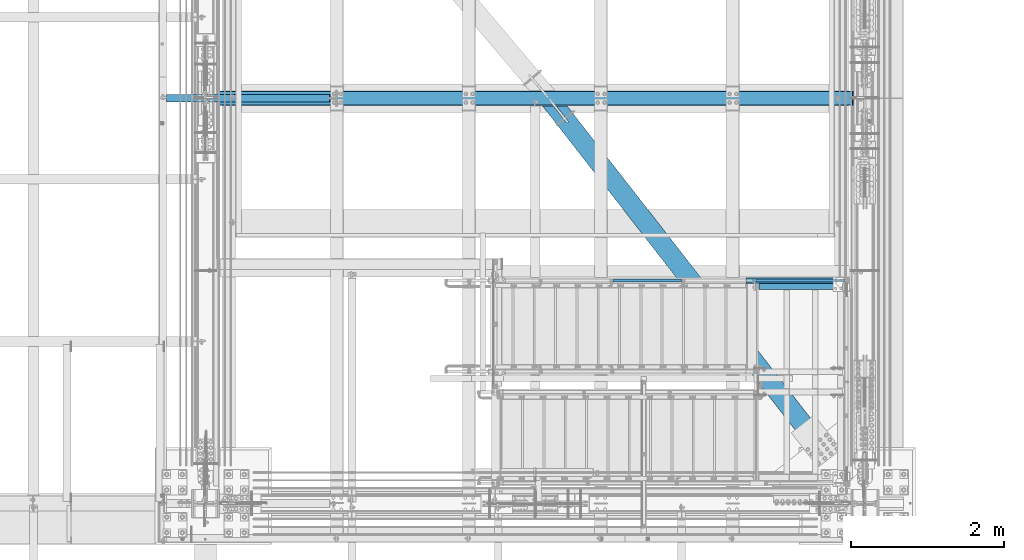
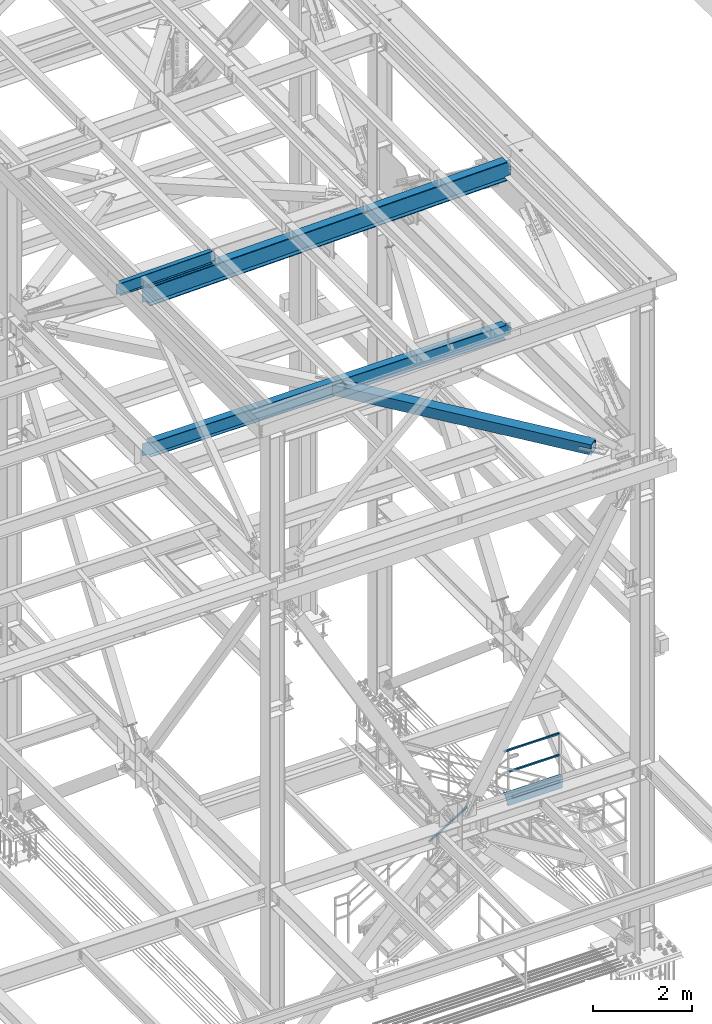
# One storey, part 1950 of 3843: 8 beams, 1 member, 6 elements without a shape of their own.
"""IFC2X3 building model written with IfcOpenShell, lengths in millimetres."""

from ifc_helpers import new_model, si_unit, frame, origin_with_axes, place, context, subcontext, project, spatial, faceted_brep, material, type_object, element, aggregate, save


model = new_model("IFC2X3")

# Units and contexts
model_context = context("Model", 3, precision=1e-05, world=origin_with_axes())
body_context = subcontext(model_context, "Body", "Model", "MODEL_VIEW")
ifc_project = project(units=[si_unit("LENGTHUNIT", "METRE", prefix="MILLI"), si_unit("AREAUNIT", "SQUARE_METRE"), si_unit("VOLUMEUNIT", "CUBIC_METRE"), si_unit("MASSUNIT", "GRAM", prefix="KILO"), si_unit("TIMEUNIT", "SECOND"), si_unit("PLANEANGLEUNIT", "RADIAN"), si_unit("SOLIDANGLEUNIT", "STERADIAN"), si_unit("THERMODYNAMICTEMPERATUREUNIT", "DEGREE_CELSIUS"), si_unit("LUMINOUSINTENSITYUNIT", "LUMEN")], contexts=[model_context])

# Site, building, storey
site_placement = place(None, origin_with_axes())
site = spatial("IfcSite", under=ifc_project, at=site_placement, CompositionType="ELEMENT")
building_placement = place(site_placement, origin_with_axes())
building = spatial("IfcBuilding", under=site, at=building_placement, Name="Undefined", CompositionType="ELEMENT")
storey_placement = place(building_placement, origin_with_axes())
storey = spatial("IfcBuildingStorey", under=building, at=storey_placement, Name="Undefined", CompositionType="ELEMENT", Elevation=0.0)

# Assembly, beams, member
assembly_1_placement = place(storey_placement, origin_with_axes())
assembly_1 = element("IfcElementAssembly", 1, at=assembly_1_placement, inside=storey, Name="RAIL", AssemblyPlace="NOTDEFINED", PredefinedType="RIGID_FRAME")
ifc_material_1 = material()
beam_type_1 = type_object("IfcBeamType", Name="HSS1-1/2X1-1/2X1/4", PredefinedType="NOTDEFINED")
beam_1_placement = place(assembly_1_placement, frame((84200.9999999997, 17919.7, 33248.5999999847), z_axis=(0.0, 0.0, 1.0), x_axis=(1.0, 0.0, 0.0)))
beam_1 = element("IfcBeam", 2, at=beam_1_placement, type_object=beam_type_1, material=ifc_material_1, Name="RAIL", ObjectType="HSS1-1/2X1-1/2X1/4", context=body_context, shape_type="Brep", body=[
    faceted_brep([(19.0499992350015, -19.0499992350015, -19.0499992350015), (19.0499992350015, -19.0499992350015, 19.0499992350015), (19.0499992350015, 19.0499992350015, 19.0499992350015), (19.0499992350015, 19.0499992350015, -19.0499992350015), (19.0499992350015, 12.6999993299978, 12.6999993299978), (19.0499992350015, -12.6999993299978, 12.6999993299978), (19.0499992350015, -12.6999993299978, -12.6999993299978), (19.0499992350015, 12.6999993299978, -12.6999993299978), (1187.45000073145, 19.0499992350015, -19.0499992350015), (1187.45000073145, -19.0499992350015, -19.0499992350015), (1187.45000073145, -19.0499992350015, 19.0499992350015), (1187.45000073145, 19.0499992350015, 19.0499992350015), (1187.44999761864, -12.6999993299978, 12.6999993300014), (1187.44999761864, 12.6999993299978, 12.6999993300014), (1187.44999761864, 12.6999993299978, -12.6999993300014), (1187.44999761864, -12.6999993299978, -12.6999993300014)], [[[0, 1, 2, 3], [4, 5, 6, 7]], [[8, 9, 0, 3]], [[9, 10, 1, 0]], [[10, 11, 2, 1]], [[11, 8, 3, 2]], [[10, 9, 8, 11], [12, 13, 14, 15]], [[13, 12, 5, 4]], [[14, 13, 4, 7]], [[15, 14, 7, 6]], [[12, 15, 6, 5]]]),
])
beam_2_placement = place(assembly_1_placement, frame((85255.0999999997, 17919.7, 33781.9999999847), z_axis=(0.0, 0.0, -1.0), x_axis=(-1.0, 0.0, 0.0)))
beam_2 = element("IfcBeam", 3, at=beam_2_placement, type_object=beam_type_1, material=ifc_material_1, Name="RAIL", ObjectType="HSS1-1/2X1-1/2X1/4", context=body_context, shape_type="Brep", body=[
    faceted_brep([(-133.350000731458, 12.6999993300014, -12.6999993299978), (-133.350000731458, -12.6999993300014, -12.6999993299978), (1159.29463566931, -12.6999993300014, -12.6999993299978), (1159.29463566931, 12.6999993300014, -12.6999993299978), (-133.350000731458, -12.6999993300014, 12.6999993299978), (1152.10536442048, -12.6999993300014, 12.6999993299978), (-133.350000731458, 12.6999993300014, 12.6999993299978), (1152.10536442048, 12.6999993300014, 12.6999993299978), (-133.350000731458, 19.0499992350015, -19.0499992350015), (-133.350000731458, 19.0499992350015, 19.0499992350015), (1150.30804654033, 19.0499992350015, 19.0499992350015), (1161.09195354945, 19.0499992350015, -19.0499992350015), (-133.350000731458, -19.0499992350015, 19.0499992350015), (1150.30804654033, -19.0499992350015, 19.0499992350015), (-133.350000731458, -19.0499992350015, -19.0499992350015), (1161.09195354945, -19.0499992350015, -19.0499992350015)], [[[0, 1, 2, 3]], [[1, 4, 5, 2]], [[4, 6, 7, 5]], [[6, 0, 3, 7]], [[8, 9, 10, 11]], [[9, 12, 13, 10]], [[12, 14, 15, 13]], [[14, 8, 11, 15]], [[13, 15, 11, 10], [5, 7, 3, 2]], [[14, 12, 9, 8], [6, 4, 1, 0]]]),
])
member_type = type_object("IfcMemberType", Name="HSS1-1/2X1-1/2X1/4", PredefinedType="NOTDEFINED")
member_placement = place(assembly_1_placement, frame((82334.1000000268, 17919.7, 32162.2615381769), z_axis=(-0.524097425775922, 0.0, 0.851658316635875), x_axis=(0.851658316635872, 0.0, 0.524097425775926)))
member = element("IfcMember", 4, at=member_placement, type_object=member_type, material=ifc_material_1, Name="RAIL", ObjectType="HSS1-1/2X1-1/2X1/4", context=body_context, shape_type="Brep", body=[
    faceted_brep([(1085.39309424335, -19.0499999999993, 19.0499992355599), (1061.94694133186, -19.0499992350015, -19.0499992344103), (1061.94694133186, 19.0499992350015, -19.0499992344103), (1085.39309424335, 19.0499992350015, 19.0499992355599), (1081.48540199296, -12.6999993300014, 12.6999993305635), (1081.48540199296, 12.6999993300014, 12.6999993305635), (1065.85463358223, 12.6999993300014, -12.6999993294176), (1065.85463358223, -12.6999993300014, -12.6999993294176), (10.6450480494532, 19.0499992350015, -19.0499992349796), (34.091200960931, 19.0499992350015, 19.0499992349942), (34.091200960931, -19.0499992350015, 19.0499992349942), (10.6450480494532, -19.0499992350015, -19.0499992349796), (30.1835087105574, 12.6999993300014, 12.6999993299978), (30.1835087105574, -12.6999993300014, 12.6999993299978), (14.5527402998268, -12.6999993300014, -12.6999993299833), (14.5527402998268, 12.6999993300014, -12.6999993299833)], [[[0, 1, 2, 3], [4, 5, 6, 7]], [[8, 9, 3, 2]], [[9, 10, 0, 3]], [[10, 11, 1, 0]], [[11, 8, 2, 1]], [[11, 10, 9, 8], [12, 13, 14, 15]], [[14, 13, 4, 7]], [[15, 14, 7, 6]], [[12, 15, 6, 5]], [[13, 12, 5, 4]]]),
])
aggregate(assembly_1, [beam_1, member, beam_2])

# Assembly, beams
assembly_2_placement = place(storey_placement, origin_with_axes())
assembly_2 = element("IfcElementAssembly", 5, at=assembly_2_placement, inside=storey, Name="STAIR", AssemblyPlace="NOTDEFINED", PredefinedType="RIGID_FRAME")
ifc_material_2 = material(Name="STEEL/A36")
beam_type_2 = type_object("IfcBeamType", Name="C12X20.7", PredefinedType="NOTDEFINED")
beam_3_placement = place(assembly_2_placement, frame((85445.6000000098, 17919.7000000543, 32588.1999999996), z_axis=(0.0, 0.0, 1.0), x_axis=(-1.0, 0.0, 0.0)))
beam_3 = element("IfcBeam", 6, at=beam_3_placement, type_object=beam_type_2, material=ifc_material_2, Name="STAIR", ObjectType="C12X20.7", context=body_context, shape_type="Brep", body=[
    faceted_brep([(0.0, 38.0999999999985, -152.400000000001), (0.0, 38.0999999999985, 152.400000000001), (1353.38927165531, 38.0999999999985, 152.400000000001), (1267.11801211795, 38.0999999999985, -152.400000000001), (0.0, -38.0999999999985, 152.400000000001), (1353.38927165531, -38.0999999999985, 152.400000000001), (0.0, -38.0999999999985, 146.047460000002), (1351.59123482111, -38.0999999999985, 146.047460000002), (0.0, 30.1624999999985, 134.6749275), (1348.37232831553, 30.1624999999985, 134.6749275), (0.0, 30.1624999999985, -134.6749275), (1272.13495545773, 30.1624999999985, -134.6749275), (0.0, -38.0999999999985, -146.047460000002), (1268.91604895213, -38.0999999999985, -146.047460000002), (0.0, -38.0999999999985, -152.400000000001), (1267.11801211795, -38.0999999999985, -152.400000000001)], [[[0, 1, 2, 3]], [[1, 4, 5, 2]], [[4, 6, 7, 5]], [[6, 8, 9, 7]], [[8, 10, 11, 9]], [[10, 12, 13, 11]], [[12, 14, 15, 13]], [[14, 0, 3, 15]], [[5, 7, 9, 11, 13, 15, 3, 2]], [[14, 12, 10, 8, 6, 4, 1, 0]]]),
])
beam_type_3 = type_object("IfcBeamType", Name="L3X3X1/4", PredefinedType="NOTDEFINED")
beam_4_placement = place(assembly_2_placement, frame((84264.4999997904, 17843.5000000543, 32626.3000003847), z_axis=(0.0, -1.0, 0.0), x_axis=(1.0, 0.0, 0.0)))
beam_4 = element("IfcBeam", 7, at=beam_4_placement, type_object=beam_type_3, material=ifc_material_2, Name="ANGLE", ObjectType="L3X3X1/4", context=body_context, shape_type="Brep", body=[
    faceted_brep([(0.0, 38.0999999999985, -38.0999999999985), (0.0, 38.0999999999985, 38.0999999999985), (1082.6750002124, 38.0999999999985, 38.0999999999985), (1082.6750002124, 38.0999999999985, -38.0999999999985), (0.0, 31.75, 38.0999999999985), (1082.6750002124, 31.75, 38.0999999999985), (0.0, 31.75, -31.75), (1082.6750002124, 31.75, -31.75), (0.0, -38.0999999999985, -31.75), (1082.6750002124, -38.0999999999985, -31.75), (0.0, -38.0999999999985, -38.0999999999985), (1082.6750002124, -38.0999999999985, -38.0999999999985)], [[[0, 1, 2, 3]], [[1, 4, 5, 2]], [[4, 6, 7, 5]], [[6, 8, 9, 7]], [[8, 10, 11, 9]], [[10, 0, 3, 11]], [[5, 7, 9, 11, 3, 2]], [[10, 8, 6, 4, 1, 0]]]),
])
aggregate(assembly_2, [beam_3, beam_4])

# Assembly, beam
assembly_3_placement = place(storey_placement, origin_with_axes())
assembly_3 = element("IfcElementAssembly", 8, at=assembly_3_placement, inside=storey, Name="BEAM", AssemblyPlace="NOTDEFINED", PredefinedType="RIGID_FRAME")
ifc_material_3 = material(Name="STEEL/A992")
beam_type_4 = type_object("IfcBeamType", Name="W12X19", PredefinedType="NOTDEFINED")
beam_5_placement = place(assembly_3_placement, frame((76406.4571596645, 20307.3, 46418.2589406468), z_axis=(-0.0211520980073474, 0.0, 0.999776269347241), x_axis=(0.999776270257024, 0.0, 0.0211520550054619)))
beam_5 = element("IfcBeam", 9, at=beam_5_placement, type_object=beam_type_4, material=ifc_material_3, Name="BEAM", ObjectType="W12X19", context=body_context, shape_type="Brep", body=[
    faceted_brep([(2232.3149825334, -3.17500000000291, -144.462499991867), (2232.3149825334, -50.8000000000029, -144.462499991867), (2232.31498253353, -50.8000000000029, -153.987499991876), (2232.31498253353, 50.8000000000029, -153.987499991876), (2232.3149825334, 50.8000000000029, -144.462499991867), (2232.3149825334, 3.17500000000291, -144.462499991867), (2232.31498253338, 3.17500000000291, -141.287499725579), (2232.31498253338, -3.17500000000291, -141.287499725579), (2233.28171245592, 3.17500000000291, -136.427420207467), (2233.28171245592, -3.17500000000291, -136.427420207467), (2236.03472635635, 3.17500000000291, -132.307243739255), (2236.03472635635, -3.17500000000291, -132.307243739255), (2240.15490282445, 3.17500000000291, -129.554229838737), (2240.15490282445, -3.17500000000291, -129.554229838737), (2245.01498234246, 3.17500000000291, -128.587499916146), (2245.01498234246, -3.17500000000291, -128.587499916146), (2314.86498100203, -3.17500000000291, -128.587499916357), (2314.86498100203, 3.17500000000291, -128.587499916357), (96.8374980314547, 3.17500000000291, 144.462500000489), (96.8374980314547, 50.8000000000029, 144.462500000489), (2232.31498253648, 50.8000000000029, 144.462500008405), (2232.31498253648, 3.17500000000291, 144.462500008405), (96.8374977455387, -3.17500000000291, -141.287499907492), (96.8374977455387, 3.17500000000291, -141.287499907492), (96.8374977423518, 3.17500000000291, -144.462499999776), (96.8374977423518, 50.8000000000029, -144.462499999776), (96.8374977328203, 50.8000000000029, -153.987499999792), (96.8374977328203, -50.8000000000029, -153.987499999792), (96.8374977423518, -50.8000000000029, -144.462499999776), (96.8374977423518, -3.17500000000291, -144.462499999776), (95.8707678278151, -3.17500000000291, -136.427420388471), (95.8707678278151, 3.17500000000291, -136.427420388471), (93.1177539315104, -3.17500000000291, -132.307243917545), (93.1177539315104, 3.17500000000291, -132.307243917545), (88.9975774661289, -3.17500000000291, -129.554230012938), (88.9975774661289, 3.17500000000291, -129.554230012938), (84.1374979491229, -3.17500000000291, -128.587500085479), (84.1374979491229, 3.17500000000291, -128.587500085479), (20.6374979119428, -3.17500000000291, -128.587500021946), (20.6374979119428, 3.17500000000291, -128.587500021946), (20.637499711811, -3.17500000000291, 128.587499979069), (20.637499711811, 3.17500000000291, 128.587499979069), (20.6374996229279, 3.17500000000291, 115.88750024372), (20.6374980090477, 3.17500000000291, -114.712499752241), (84.1374982064444, -3.17500000000291, 128.587499915513), (84.1374982064444, 3.17500000000291, 128.587499915513), (88.9975777254003, -3.17500000000291, 129.554229833244), (88.9975777254003, 3.17500000000291, 129.554229833244), (93.1177541962679, -3.17500000000291, 132.307243729607), (93.1177541962679, 3.17500000000291, 132.307243729607), (95.8707681008382, -3.17500000000291, 136.427420195025), (95.8707681008382, 3.17500000000291, 136.427420195025), (96.8374980282824, -3.17500000000291, 141.287499712118), (96.8374980282824, 3.17500000000291, 141.287499712118), (96.8374980410154, -50.8000000000029, 153.987499285155), (96.8374980410008, 50.8000000000029, 153.987500000498), (96.8374980314547, -3.17500000000291, 144.462500000489), (96.8374980314547, -50.8000000000029, 144.462500000489), (2232.31498253648, -3.17500000000291, 144.462500008405), (2232.31498253648, -50.8000000000029, 144.462500008405), (2232.31498253638, -50.8000000000029, 153.987499981791), (2232.31498253639, 50.8000000000029, 153.987500008421), (2232.31498253651, -3.17500000000291, 141.28749989366), (2232.31498253651, 3.17500000000291, 141.28749989366), (2233.28171245912, -3.17500000000291, 136.427420375658), (2233.28171245912, 3.17500000000291, 136.427420375658), (2236.03472635955, -3.17500000000291, 132.30724390754), (2236.03472635955, 3.17500000000291, 132.30724390754), (2240.15490282758, -3.17500000000291, 129.554230007096), (2240.15490282758, 3.17500000000291, 129.554230007096), (2245.0149823455, -3.17500000000291, 128.587500084504), (2245.0149823455, 3.17500000000291, 128.587500084504), (2314.86498280188, -3.17500000000291, 128.58750008425), (2314.86498280188, 3.17500000000291, 128.58750008425)], [[[0, 1, 2, 3, 4, 5, 6, 7]], [[7, 6, 8, 9]], [[9, 8, 10, 11]], [[11, 10, 12, 13]], [[13, 12, 14, 15]], [[16, 15, 14, 17]], [[18, 19, 20, 21]], [[22, 23, 24, 25, 26, 27, 28, 29]], [[30, 31, 23, 22]], [[32, 33, 31, 30]], [[34, 35, 33, 32]], [[36, 37, 35, 34]], [[38, 39, 37, 36]], [[40, 41, 42, 43, 39, 38]], [[44, 45, 41, 40]], [[46, 47, 45, 44]], [[48, 49, 47, 46]], [[50, 51, 49, 48]], [[52, 53, 51, 50]], [[54, 55, 19, 18, 53, 52, 56, 57]], [[57, 56, 58, 59]], [[54, 57, 59, 60]], [[55, 54, 60, 61]], [[19, 55, 61, 20]], [[60, 59, 58, 62, 63, 21, 20, 61]], [[64, 65, 63, 62]], [[66, 67, 65, 64]], [[68, 69, 67, 66]], [[70, 71, 69, 68]], [[72, 73, 71, 70]], [[73, 72, 16, 17]], [[12, 10, 8, 6, 5, 24, 23, 31, 33, 35, 37, 39, 43, 42, 41, 45, 47, 49, 51, 53, 18, 21, 63, 65, 67, 69, 71, 73, 17, 14]], [[25, 24, 5, 4]], [[26, 25, 4, 3]], [[27, 26, 3, 2]], [[28, 27, 2, 1]], [[29, 28, 1, 0]], [[72, 70, 68, 66, 64, 62, 58, 56, 52, 50, 48, 46, 44, 40, 38, 36, 34, 32, 30, 22, 29, 0, 7, 9, 11, 13, 15, 16]]]),
])
aggregate(assembly_3, [beam_5])

assembly_4_placement = place(storey_placement, origin_with_axes())
assembly_4 = element("IfcElementAssembly", 10, at=assembly_4_placement, inside=storey, Name="BEAM", AssemblyPlace="NOTDEFINED", PredefinedType="RIGID_FRAME")
beam_type_5 = type_object("IfcBeamType", Name="W18X65", PredefinedType="NOTDEFINED")
beam_6_placement = place(assembly_4_placement, frame((77017.7361061486, 20307.3, 46040.5792898811), z_axis=(-0.0211520980073474, 0.0, 0.999776269347241), x_axis=(0.999776270257024, 0.0, 0.0211520550054619)))
beam_6 = element("IfcBeam", 11, at=beam_6_placement, type_object=beam_type_5, material=ifc_material_3, Name="BEAM", ObjectType="W18X65", context=body_context, shape_type="Brep", body=[
    faceted_brep([(9.33848262824176, -5.55625000000146, -150.812499998887), (9.33848262824176, 5.55625000000146, -150.812499998887), (121.89198638963, 5.55625000000146, -150.81249999885), (121.89198638963, -5.55625000000146, -150.81249999885), (126.752065907756, 5.55625000000146, -151.779229921442), (126.752065907756, -5.55625000000146, -151.779229921442), (130.87224237599, 5.55625000000146, -154.532243821901), (130.87224237599, -5.55625000000146, -154.532243821901), (133.625256276515, 5.55625000000146, -158.652420290033), (133.625256276515, -5.55625000000146, -158.652420290033), (134.591986199128, -5.55625000000146, -163.51249980805), (134.591986199128, 5.55625000000146, -163.51249980805), (134.591986199172, 5.55625000000146, -214.312499999527), (134.591986199172, 96.8375000000015, -214.312499999527), (134.591986199201, 96.8375000000015, -233.362499999508), (134.591986199201, -96.8375000000015, -233.362499999508), (134.591986199172, -96.8375000000015, -214.312499999527), (134.591986199172, -5.55625000000146, -214.312499999527), (8483.94045331146, 96.8375000000015, 214.312500006869), (8483.94045331146, 5.55625000000146, 214.312500006869), (134.591986198662, 5.55625000000146, 214.312499999774), (134.591986198662, 96.8375000000015, 214.312499999774), (121.891986389208, -5.55625000000146, 201.612499999304), (121.891986389208, 5.55625000000146, 201.612499999304), (16.7946789481648, 5.55625000000146, 201.61249999921), (16.7946789481648, -5.55625000000146, 201.61249999921), (126.75206590732, -5.55625000000146, 202.579229921888), (126.75206590732, 5.55625000000146, 202.579229921888), (130.872242375539, -5.55625000000146, 205.332243822348), (130.872242375539, 5.55625000000146, 205.332243822348), (133.625256276049, -5.55625000000146, 209.452420290487), (133.625256276049, 5.55625000000146, 209.452420290487), (134.591986198662, -5.55625000000146, 214.312499999774), (8483.94045331144, -96.8375000000015, 233.362500006835), (8483.94045331144, 96.8375000000015, 233.362500006835), (134.591986198648, 96.8375000000015, 233.362499999748), (134.591986198648, -96.8375000000015, 233.362499999748), (8483.94045331146, -96.8375000000015, 214.312500006869), (134.591986198662, -96.8375000000015, 214.312499999774), (8483.94045331146, -5.55625000000146, 214.312500006869), (8483.94045331149, -5.55625000000146, 201.612499953568), (8483.94045331149, 5.55625000000146, 201.612499953568), (8484.9071832341, -5.55625000000146, 196.752420435558), (8484.9071832341, 5.55625000000146, 196.752420435558), (8487.66019713462, -5.55625000000146, 192.632243967419), (8487.66019713462, 5.55625000000146, 192.632243967419), (8491.78037360284, -5.55625000000146, 189.879230066967), (8491.78037360284, 5.55625000000146, 189.879230066967), (8496.64045312097, -5.55625000000146, 188.912500144383), (8496.64045312097, 5.55625000000146, 188.912500144383), (8616.35003128365, -5.55625000000146, 188.912500144485), (8616.35003128365, 5.55625000000146, 188.912500144485), (8609.71183290241, 5.55625000000146, -124.848962686272), (8616.2012965711, 5.55625000000146, 181.882396748464), (8608.35645144517, -5.55625000000146, -188.912499853563), (8608.35645144517, 5.55625000000146, -188.912499853563), (8490.29045312117, -5.55625000000146, -188.912499853599), (8490.29045312117, 5.55625000000146, -188.912499853599), (8485.43037360304, -5.55625000000146, -189.879229776183), (8485.43037360304, 5.55625000000146, -189.879229776183), (8481.31019713482, -5.55625000000146, -192.632243676657), (8481.31019713482, 5.55625000000146, -192.632243676657), (8478.5571832343, -5.55625000000146, -196.752420144789), (8478.5571832343, 5.55625000000146, -196.752420144789), (8477.5904533117, -5.55625000000146, -201.612499662813), (8477.5904533117, 5.55625000000146, -201.612499662813), (8477.59045331171, -5.55625000000146, -214.312499992448), (8477.59045331171, -96.8375000000015, -214.312499992448), (8477.59045331174, -96.8375000000015, -233.362499992414), (8477.59045331174, 96.8375000000015, -233.362499992414), (8477.59045331171, 96.8375000000015, -214.312499992448), (8477.59045331171, 5.55625000000146, -214.312499992448), (9.64751402361435, 5.55625000000146, -136.205804461417), (16.1369776922947, 5.55625000000146, 170.525554973312)], [[[0, 1, 2, 3]], [[3, 2, 4, 5]], [[5, 4, 6, 7]], [[7, 6, 8, 9]], [[10, 11, 12, 13, 14, 15, 16, 17]], [[9, 8, 11, 10]], [[18, 19, 20, 21]], [[22, 23, 24, 25]], [[26, 27, 23, 22]], [[28, 29, 27, 26]], [[30, 31, 29, 28]], [[32, 20, 31, 30]], [[33, 34, 35, 36]], [[37, 33, 36, 38]], [[39, 37, 38, 32]], [[36, 35, 21, 20, 32, 38]], [[34, 18, 21, 35]], [[33, 37, 39, 40, 41, 19, 18, 34]], [[42, 43, 41, 40]], [[44, 45, 43, 42]], [[46, 47, 45, 44]], [[48, 49, 47, 46]], [[50, 51, 49, 48]], [[52, 53, 51, 50, 54, 55]], [[54, 56, 57, 55]], [[58, 59, 57, 56]], [[60, 61, 59, 58]], [[62, 63, 61, 60]], [[64, 65, 63, 62]], [[66, 67, 68, 69, 70, 71, 65, 64]], [[67, 66, 17, 16]], [[68, 67, 16, 15]], [[69, 68, 15, 14]], [[70, 69, 14, 13]], [[71, 70, 13, 12]], [[6, 4, 2, 1, 72, 73, 24, 23, 27, 29, 31, 20, 19, 41, 43, 45, 47, 49, 51, 53, 52, 55, 57, 59, 61, 63, 65, 71, 12, 11, 8]], [[25, 24, 73, 72, 1, 0]], [[66, 64, 62, 60, 58, 56, 54, 50, 48, 46, 44, 42, 40, 39, 32, 30, 28, 26, 22, 25, 0, 3, 5, 7, 9, 10, 17]]]),
])
aggregate(assembly_4, [beam_6])

assembly_5_placement = place(storey_placement, origin_with_axes())
assembly_5 = element("IfcElementAssembly", 12, at=assembly_5_placement, inside=storey, AssemblyPlace="NOTDEFINED", PredefinedType="RIGID_FRAME")
ifc_material_4 = material()
beam_type_6 = type_object("IfcBeamType", Name="HSS10X10X3/4", PredefinedType="NOTDEFINED")
beam_7_placement = place(assembly_5_placement, frame((81508.5999996814, 20307.3000000873, 42246.55), z_axis=(0.788538898871981, 0.614984881900168, 0.0), x_axis=(0.614984883006899, -0.788538898008837, 0.0)))
beam_7 = element("IfcBeam", 13, at=beam_7_placement, type_object=beam_type_6, material=ifc_material_4, ObjectType="HSS10X10X3/4", context=body_context, shape_type="Brep", body=[
    faceted_brep([(135.962343596548, -127.0, 14.287500099992), (135.962343596548, -107.949999999997, 14.287500099992), (388.374839476222, -107.949999999997, 14.2875002978253), (388.374839476222, -127.0, 14.2875002978253), (393.84243002619, -107.949999999997, 13.1999287362996), (393.84243002619, -127.0, 13.1999287362996), (398.477629206835, -107.949999999997, 10.1027870089747), (398.477629206835, -127.0, 10.1027870089747), (401.574769729079, -107.949999999997, 5.46758702315856), (401.574769729079, -127.0, 5.46758702315856), (388.374833543305, -127.0, -14.2874937463057), (388.374833543305, -107.949999999997, -14.2874937463057), (113.676671985537, -107.949999999997, -14.2873794580373), (113.676671985537, -127.0, -14.2873794580373), (393.842424194067, -127.0, -13.1999246006162), (393.842424194067, -107.949999999997, -13.1999246006162), (398.477624474617, -127.0, -10.1027851898252), (398.477624474617, -107.949999999997, -10.1027851898252), (401.574767022714, -127.0, -5.4675870056235), (401.574767022714, -107.949999999997, -5.4675870056235), (402.662339869072, -127.0, -3.80947312805802e-06), (402.662339869072, -107.949999999997, -3.80947312805802e-06), (135.962343596548, 107.949999999997, 14.287500099992), (135.962343596548, 127.0, 14.287500099992), (388.374839476222, 127.0, 14.2875002978253), (388.374839476222, 107.949999999997, 14.2875002978253), (393.84243002619, 127.0, 13.1999287362996), (393.84243002619, 107.949999999997, 13.1999287362996), (398.477629206835, 127.0, 10.1027870089747), (398.477629206835, 107.949999999997, 10.1027870089747), (401.574769729079, 127.0, 5.46758702315856), (401.574769729079, 107.949999999997, 5.46758702315856), (388.374833543305, 107.949999999997, -14.2874937463057), (388.374833543305, 127.0, -14.2874937463057), (113.676671985537, 127.0, -14.2873794580373), (113.676671985537, 107.949999999997, -14.2873794580373), (393.842424194067, 107.949999999997, -13.1999246006162), (393.842424194067, 127.0, -13.1999246006162), (398.477624474617, 107.949999999997, -10.1027851898252), (398.477624474617, 127.0, -10.1027851898252), (401.574767022714, 107.949999999997, -5.4675870056235), (401.574767022714, 127.0, -5.4675870056235), (402.662339869072, 107.949999999997, -3.80947312805802e-06), (402.662339869072, 127.0, -3.80947312805802e-06), (209.010130579474, -107.949999999997, 107.949999999197), (5662.43509653087, -107.949999999997, 107.949999994526), (5662.43509653184, -107.949999999997, -107.950000004188), (40.6287909132807, -107.949999999997, -107.949999999386), (5662.43509653079, -127.0, 126.999999994412), (5662.43509653192, -127.0, -127.000000004075), (5662.43509653192, -26.9874999999956, -127.000000004075), (5662.43509653184, -26.9874999999956, -107.950000004188), (5662.43509653087, -26.9874999999956, 107.949999994526), (5662.43509653079, -26.9874999999956, 126.999999994412), (5404.55500715419, -25.8999287917104, -107.950000003984), (5399.91980843416, -22.8027880244699, -107.95000000397), (5396.82266766691, -18.167589304423, -107.95000000397), (5395.73509645863, -12.6999996185259, -107.95000000397), (5396.82266766691, -7.23241069557116, -107.95000000397), (5399.91980843416, -2.59721197552426, -107.95000000397), (5404.55500715419, 0.499928791716229, -107.950000003984), (5410.02259684008, 1.58750000000146, -107.95000000397), (5662.43509653184, 1.58750000000146, -107.950000004188), (5662.43509653184, 107.949999999997, -107.950000004188), (40.6287909132807, 107.949999999997, -107.949999999386), (5410.02259684008, -26.9874999999956, -107.95000000397), (5410.02259684024, 1.58750000000146, -127.000000003871), (5662.43509653192, 1.58750000000146, -127.000000004075), (5404.55500715435, 0.499928791716229, -127.000000003871), (5399.91980843431, -2.59721197552426, -127.000000003856), (5396.82266766706, -7.23241069557116, -127.000000003856), (5395.73509645878, -12.6999996185259, -127.000000003856), (5396.82266766706, -18.167589304423, -127.000000003856), (5399.91980843431, -22.8027880244699, -127.000000003856), (5404.55500715435, -25.8999287917104, -127.000000003871), (5410.02259684024, -26.9874999999956, -127.000000003871), (25.7716138839096, -127.0, -126.999999999258), (25.7716138839096, 127.0, -126.999999999258), (5662.43509653192, 127.0, -127.000000004075), (223.867307608845, 127.0, 126.999999999069), (5662.43509653079, 127.0, 126.999999994412), (5662.43509653087, 107.949999999997, 107.949999994526), (5662.43509653079, 1.58750000000146, 126.999999994412), (5662.43509653087, 1.58750000000146, 107.949999994526), (209.010130579474, 107.949999999997, 107.949999999197), (5410.02259683834, 1.58750000000146, 107.949999994729), (5404.55500715245, 0.499928791716229, 107.949999994744), (5399.9198084324, -2.59721197552426, 107.949999994744), (5396.82266766517, -7.23241069557116, 107.949999994758), (5395.73509645688, -12.6999996185259, 107.949999994744), (5396.82266766517, -18.167589304423, 107.949999994758), (5399.9198084324, -22.8027880244699, 107.949999994744), (5404.55500715245, -25.8999287917104, 107.949999994744), (5410.02259683834, -26.9874999999956, 107.949999994729), (5410.02259683819, 1.58750000000146, 126.99999999463), (5404.5550071523, 0.499928791716229, 126.99999999463), (5399.91980843225, -2.59721197552426, 126.999999994645), (5396.82266766502, -7.23241069557116, 126.999999994645), (5395.73509645673, -12.6999996185259, 126.999999994645), (5396.82266766502, -18.167589304423, 126.999999994645), (5399.91980843225, -22.8027880244699, 126.999999994645), (5404.5550071523, -25.8999287917104, 126.99999999463), (5410.02259683819, -26.9874999999956, 126.99999999463), (223.867307608845, -127.0, 126.999999999069)], [[[0, 1, 2, 3]], [[3, 2, 4, 5]], [[5, 4, 6, 7]], [[7, 6, 8, 9]], [[10, 11, 12, 13]], [[14, 15, 11, 10]], [[16, 17, 15, 14]], [[18, 19, 17, 16]], [[20, 21, 19, 18]], [[9, 8, 21, 20]], [[22, 23, 24, 25]], [[25, 24, 26, 27]], [[27, 26, 28, 29]], [[29, 28, 30, 31]], [[32, 33, 34, 35]], [[36, 37, 33, 32]], [[38, 39, 37, 36]], [[40, 41, 39, 38]], [[42, 43, 41, 40]], [[31, 30, 43, 42]], [[6, 4, 2, 1, 44, 45, 46, 47, 12, 11, 15, 17, 19, 21, 8]], [[48, 49, 50, 51, 46, 45, 52, 53]], [[54, 55, 56, 57, 58, 59, 60, 61, 62, 63, 64, 47, 46, 51, 65]], [[62, 61, 66, 67]], [[60, 68, 66, 61]], [[59, 69, 68, 60]], [[58, 70, 69, 59]], [[57, 71, 70, 58]], [[56, 72, 71, 57]], [[55, 73, 72, 56]], [[54, 74, 73, 55]], [[65, 75, 74, 54]], [[51, 50, 75, 65]], [[49, 76, 77, 78, 67, 66, 68, 69, 70, 71, 72, 73, 74, 75, 50]], [[47, 64, 35, 34, 77, 76, 13, 12]], [[28, 26, 24, 23, 79, 80, 78, 77, 34, 33, 37, 39, 41, 43, 30]], [[81, 63, 62, 67, 78, 80, 82, 83]], [[45, 44, 84, 81, 83, 85, 86, 87, 88, 89, 90, 91, 92, 93, 52]], [[82, 94, 85, 83]], [[95, 86, 85, 94]], [[96, 87, 86, 95]], [[97, 88, 87, 96]], [[98, 89, 88, 97]], [[99, 90, 89, 98]], [[100, 91, 90, 99]], [[101, 92, 91, 100]], [[102, 93, 92, 101]], [[53, 52, 93, 102]], [[101, 100, 99, 98, 97, 96, 95, 94, 82, 80, 79, 103, 48, 53, 102]], [[16, 14, 10, 13, 76, 49, 48, 103, 0, 3, 5, 7, 9, 20, 18]], [[103, 79, 23, 22, 84, 44, 1, 0]], [[38, 36, 32, 35, 64, 63, 81, 84, 22, 25, 27, 29, 31, 42, 40]]]),
])
aggregate(assembly_5, [beam_7])

assembly_6_placement = place(storey_placement, origin_with_axes())
assembly_6 = element("IfcElementAssembly", 14, at=assembly_6_placement, inside=storey, Name="BEAM", AssemblyPlace="NOTDEFINED", PredefinedType="RIGID_FRAME")
beam_type_7 = type_object("IfcBeamType", Name="W14X34", PredefinedType="NOTDEFINED")
beam_8_placement = place(assembly_6_placement, frame((77012.8, 20307.3, 42246.55), z_axis=(0.0, 0.0, 1.0), x_axis=(1.0, 0.0, 0.0)))
beam_8 = element("IfcBeam", 15, at=beam_8_placement, type_object=beam_type_7, material=ifc_material_3, Name="BEAM", ObjectType="W14X34", context=body_context, shape_type="Brep", body=[
    faceted_brep([(19.0500000000029, -3.96875, -152.400000000009), (19.0500000000029, 3.96875, -152.400000000009), (158.750000190747, 3.96888814302292, -152.400000000009), (158.750000190747, -3.96875, -152.400000000009), (163.610079708786, 3.96888886103261, -153.3667299226), (163.610079708786, -3.96875, -153.3667299226), (167.730256176947, 3.96889090164768, -156.119743823074), (167.730256176947, -3.96875, -156.119743823074), (170.483270077428, 3.96889395419566, -160.239920291227), (170.483270077428, -3.96875, -160.239920291227), (171.450000000012, -3.96875, -165.099999809274), (171.450000000012, 3.96889755396114, -165.099999809274), (171.450000000012, 3.96924972475972, -166.6875), (171.450000000012, 85.7249999999985, -166.6875), (171.450000000012, 85.7249999999985, -177.800000000003), (171.450000000012, -85.7249999999985, -177.800000000003), (171.450000000012, -85.7249999999985, -166.6875), (171.450000000012, -3.96875, -166.6875), (8464.55, 85.7249999999985, 166.6875), (8464.55, 3.96875, 166.6875), (171.450000000012, 3.96875, 166.6875), (171.450000000012, 85.7249999999985, 166.6875), (158.750000190747, -3.96875, 152.399999999994), (158.750000190747, 3.96866536417292, 152.399999999994), (19.0500000000029, 3.96875, 152.399999999994), (19.0500000000029, -3.96875, 152.399999999994), (163.610079708786, -3.96875, 153.366729922585), (163.610079708786, 3.96866465111816, 153.366729922585), (167.730256176947, -3.96875, 156.119743823059), (167.730256176947, 3.96866262051844, 156.119743823059), (170.483270077428, -3.96875, 160.239920291213), (170.483270077428, 3.96865958151466, 160.239920291213), (171.450000000012, -3.96875, 165.099999809259), (171.450000000012, 3.96865599675948, 165.099999809259), (8464.55, -85.7249999999985, 177.800000000003), (8464.55, 85.7249999999985, 177.800000000003), (171.450000000012, 85.7249999999985, 177.800000000003), (171.450000000012, -85.7249999999985, 177.800000000003), (8464.55, -85.7249999999985, 166.6875), (171.450000000012, -85.7249999999985, 166.6875), (8464.55, -3.96875, 166.6875), (171.450000000012, -3.96875, 166.6875), (8464.55, -3.96875, 165.099999809274), (8464.55, 3.96875, 165.099999809274), (8465.51672992259, -3.96875, 160.239920291227), (8465.51672992259, 3.96875, 160.239920291227), (8468.26974382307, -3.96875, 156.119743823074), (8468.26974382307, 3.96875, 156.119743823074), (8472.38992029123, -3.96875, 153.3667299226), (8472.38992029123, 3.96875, 153.3667299226), (8477.24999980927, -3.96875, 152.400000000009), (8477.24999980927, 3.96875, 152.400000000009), (8616.95, -3.96875, 152.400000000009), (8616.95, 3.96875, 152.400000000009), (8616.95, -3.96875, -152.399999999994), (8616.95, 3.96875, -152.399999999994), (8477.24999980927, -3.96875, -152.399999999994), (8477.24999980927, 3.96875, -152.399999999994), (8472.38992029123, -3.96875, -153.366729922585), (8472.38992029123, 3.96875, -153.366729922585), (8468.26974382307, -3.96875, -156.119743823059), (8468.26974382307, 3.96875, -156.119743823059), (8465.51672992259, -3.96875, -160.239920291213), (8465.51672992259, 3.96875, -160.239920291213), (8464.55, -3.96875, -165.099999809259), (8464.55, 3.96875, -165.099999809259), (8464.55, -3.96875, -166.6875), (8464.55, -85.7249999999985, -166.6875), (8464.55, -85.7249999999985, -177.800000000003), (8464.55, 85.7249999999985, -177.800000000003), (8464.55, 85.7249999999985, -166.6875), (8464.55, 3.96875, -166.6875)], [[[0, 1, 2, 3]], [[3, 2, 4, 5]], [[5, 4, 6, 7]], [[7, 6, 8, 9]], [[10, 11, 12, 13, 14, 15, 16, 17]], [[9, 8, 11, 10]], [[18, 19, 20, 21]], [[22, 23, 24, 25]], [[26, 27, 23, 22]], [[28, 29, 27, 26]], [[30, 31, 29, 28]], [[32, 33, 31, 30]], [[34, 35, 36, 37]], [[38, 34, 37, 39]], [[40, 38, 39, 41]], [[37, 36, 21, 20, 33, 32, 41, 39]], [[35, 18, 21, 36]], [[34, 38, 40, 42, 43, 19, 18, 35]], [[44, 45, 43, 42]], [[46, 47, 45, 44]], [[48, 49, 47, 46]], [[50, 51, 49, 48]], [[52, 53, 51, 50]], [[53, 52, 54, 55]], [[54, 56, 57, 55]], [[58, 59, 57, 56]], [[60, 61, 59, 58]], [[62, 63, 61, 60]], [[64, 65, 63, 62]], [[66, 67, 68, 69, 70, 71, 65, 64]], [[67, 66, 17, 16]], [[68, 67, 16, 15]], [[69, 68, 15, 14]], [[70, 69, 14, 13]], [[71, 70, 13, 12]], [[6, 4, 2, 1, 24, 23, 27, 29, 31, 33, 20, 19, 43, 45, 47, 49, 51, 53, 55, 57, 59, 61, 63, 65, 71, 12, 11, 8]], [[25, 24, 1, 0]], [[66, 64, 62, 60, 58, 56, 54, 52, 50, 48, 46, 44, 42, 40, 41, 32, 30, 28, 26, 22, 25, 0, 3, 5, 7, 9, 10, 17]]]),
])
aggregate(assembly_6, [beam_8])

save(model, "model.ifc")
